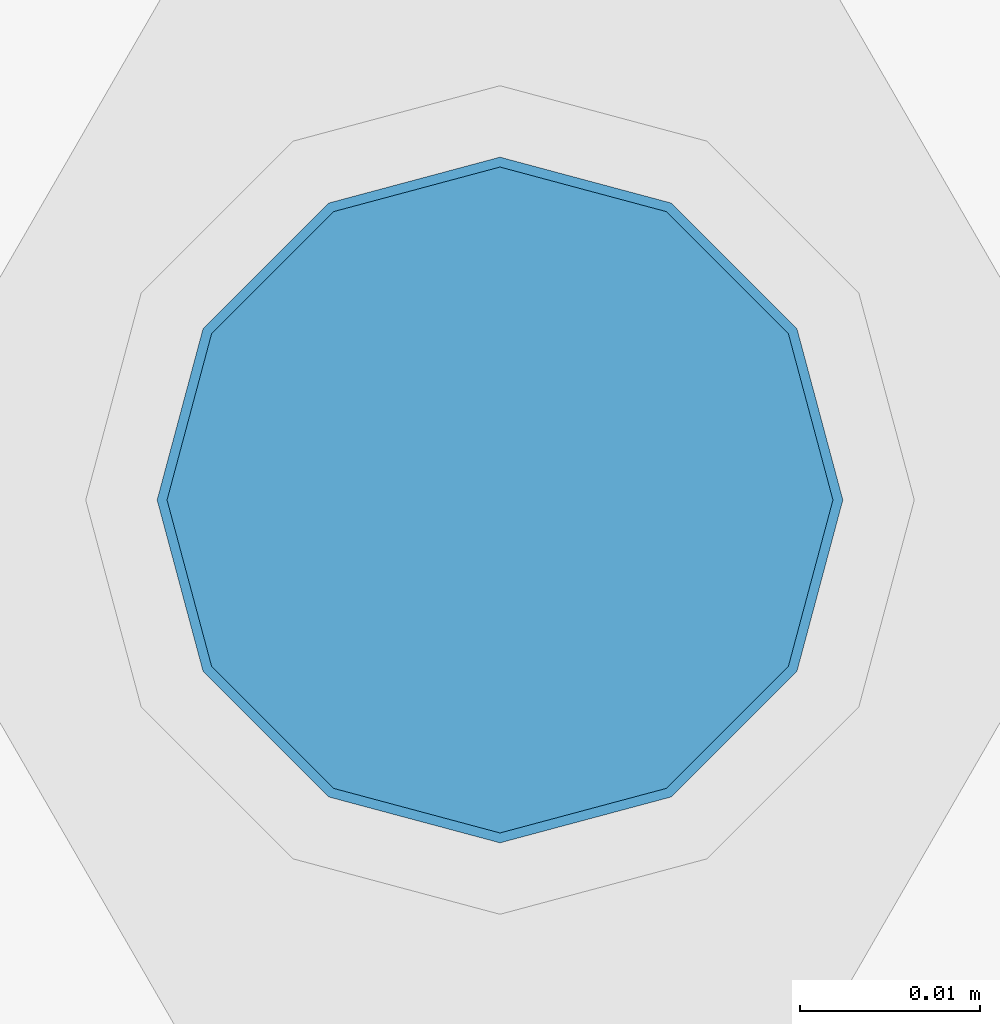
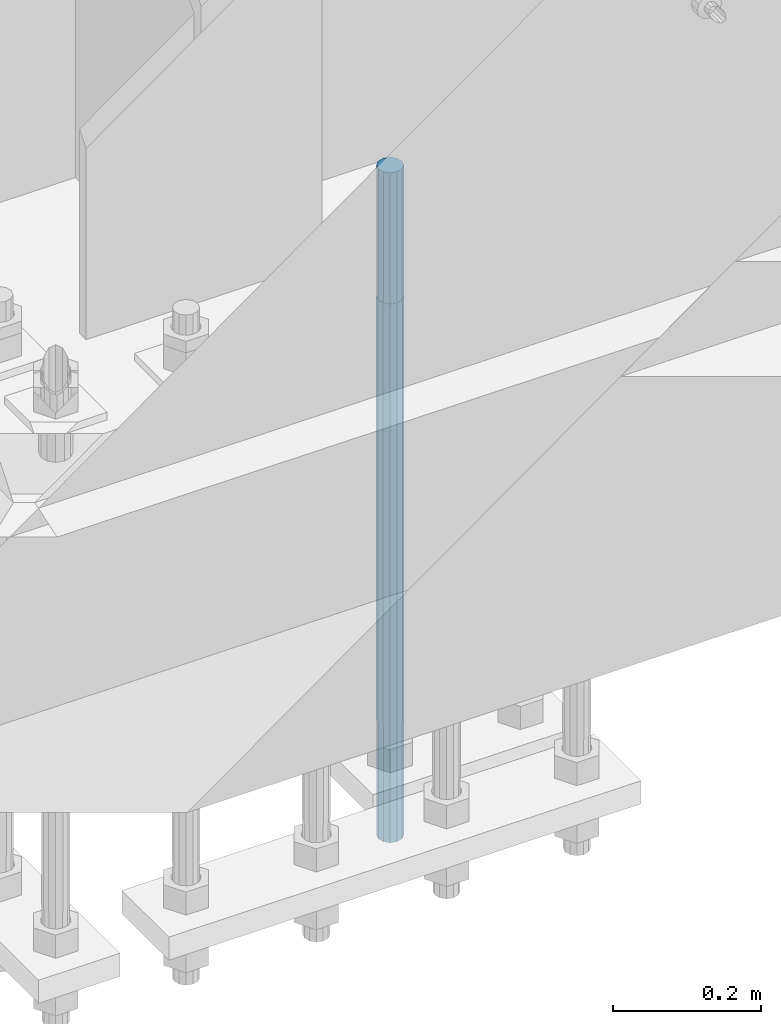
# One storey, part 1281 of 3843: 1 column, 1 element without a shape of its own.
"""IFC2X3 building model written with IfcOpenShell, lengths in millimetres."""

from ifc_helpers import new_model, si_unit, frame, origin_with_axes, place, context, subcontext, project, spatial, faceted_brep, material, type_object, element, aggregate, save


model = new_model("IFC2X3")

# Units and contexts
model_context = context("Model", 3, precision=1e-05, world=origin_with_axes())
body_context = subcontext(model_context, "Body", "Model", "MODEL_VIEW")
ifc_project = project(units=[si_unit("LENGTHUNIT", "METRE", prefix="MILLI"), si_unit("AREAUNIT", "SQUARE_METRE"), si_unit("VOLUMEUNIT", "CUBIC_METRE"), si_unit("MASSUNIT", "GRAM", prefix="KILO"), si_unit("TIMEUNIT", "SECOND"), si_unit("PLANEANGLEUNIT", "RADIAN"), si_unit("SOLIDANGLEUNIT", "STERADIAN"), si_unit("THERMODYNAMICTEMPERATUREUNIT", "DEGREE_CELSIUS"), si_unit("LUMINOUSINTENSITYUNIT", "LUMEN")], contexts=[model_context])

# Site, building, storey
site_placement = place(None, origin_with_axes())
site = spatial("IfcSite", under=ifc_project, at=site_placement, CompositionType="ELEMENT")
building_placement = place(site_placement, origin_with_axes())
building = spatial("IfcBuilding", under=site, at=building_placement, Name="Undefined", CompositionType="ELEMENT")
storey_placement = place(building_placement, origin_with_axes())
storey = spatial("IfcBuildingStorey", under=building, at=storey_placement, Name="Undefined", CompositionType="ELEMENT", Elevation=0.0)

# Assembly, column
assembly_placement = place(storey_placement, origin_with_axes())
assembly = element("IfcElementAssembly", 1, at=assembly_placement, inside=storey, Name="TEMPLATE", AssemblyPlace="NOTDEFINED", PredefinedType="RIGID_FRAME")
ifc_material = material(Name="Undefined/F1554-GR.55")
column_type = type_object("IfcColumnType", PredefinedType="NOTDEFINED")
column_placement = place(assembly_placement, frame((42367.2, 25463.5, 29565.6), z_axis=(0.0, 1.0, 0.0), x_axis=(0.0, 0.0, -1.0)))
column = element("IfcColumn", 2, at=column_placement, type_object=column_type, material=ifc_material, Name="ANCHOR_ROD", context=body_context, shape_type="Brep", body=[
    faceted_brep([(-215.899999999998, -16.0214699700118, 9.25), (-215.899999999998, -9.25, 16.0214699700155), (-215.899999999998, 0.0, 18.5), (-215.899999999998, 9.25, 16.0214699700155), (-215.899999999998, 16.0214699700118, 9.25), (-215.899999999998, 18.5, 0.0), (-215.899999999998, 16.0214699700118, -9.25), (-215.899999999998, 9.25, -16.0214699700155), (-215.899999999998, 0.0, -18.5), (-215.899999999998, -9.25, -16.0214699700155), (-215.899999999998, -16.0214699700118, -9.25), (-215.899999999998, -18.5, 0.0), (0.0, 18.5, 0.0), (0.0, 16.0214699700118, -9.25), (0.0, 9.25, -16.0214699700155), (0.0, 0.0, -18.5), (0.0, -9.25, -16.0214699700155), (0.0, -16.0214699700118, -9.25), (0.0, -18.5, 0.0), (0.0, -16.0214699700118, 9.25), (0.0, -9.25, 16.0214699700155), (0.0, 0.0, 18.5), (0.0, 9.25, 16.0214699700155), (0.0, 16.0214699700118, 9.25), (0.0, -16.4977839420972, 9.52500000000146), (0.0, -9.52500000000146, 16.4977839420972), (0.0, 0.0, 19.0499989999989), (0.0, 9.52500000000146, 16.4977839420972), (0.0, 16.4977839420972, 9.52500000000146), (0.0, 19.0500000000029, 0.0), (0.0, 16.4977839420972, -9.52500000000146), (0.0, 9.52500000000146, -16.4977839420972), (0.0, 0.0, -19.0499989999989), (0.0, -9.52500000000146, -16.4977839420972), (0.0, -16.4977839420972, -9.52500000000146), (0.0, -19.0500000000029, 0.0), (698.5, -19.0499999999993, 0.0), (698.5, -16.4977839420935, 9.52499999999418), (698.5, -9.52500000000146, 16.4977839420899), (698.5, 0.0, 19.0500000000029), (698.5, 9.52500000000146, 16.4977839420899), (698.5, 16.4977839420935, 9.52499999999418), (698.5, 19.0499999999993, 0.0), (698.5, 16.4977839420935, -9.52499999999418), (698.5, 9.52500000000146, -16.4977839420899), (698.5, 0.0, -19.0500000000029), (698.5, -9.52500000000146, -16.4977839420899), (698.5, -16.4977839420935, -9.52499999999418), (698.5, -9.25, 16.0214699700155), (698.5, 0.0, 18.5), (698.5, 9.25, 16.0214699700155), (698.5, 16.0214699700118, 9.25), (698.5, 18.5, 0.0), (698.5, 16.0214699700118, -9.25), (698.5, 9.25, -16.0214699700155), (698.5, 0.0, -18.5), (698.5, -9.25, -16.0214699700155), (698.5, -16.0214699700118, -9.25), (698.5, -18.5, 0.0), (698.5, -16.0214699700118, 9.25), (889.0, -9.25, -16.0214699700155), (889.0, 0.0, -18.5), (889.0, 9.25, -16.0214699700155), (889.0, 16.0214699700118, -9.25), (889.0, 18.5, 0.0), (889.0, 16.0214699700118, 9.25), (889.0, 9.25, 16.0214699700155), (889.0, 0.0, 18.5), (889.0, -9.25, 16.0214699700155), (889.0, -16.0214699700118, 9.25), (889.0, -18.5, 0.0), (889.0, -16.0214699700118, -9.25)], [[[0, 1, 2, 3, 4, 5, 6, 7, 8, 9, 10, 11]], [[6, 5, 12, 13]], [[7, 6, 13, 14]], [[8, 7, 14, 15]], [[9, 8, 15, 16]], [[10, 9, 16, 17]], [[11, 10, 17, 18]], [[0, 11, 18, 19]], [[1, 0, 19, 20]], [[2, 1, 20, 21]], [[3, 2, 21, 22]], [[4, 3, 22, 23]], [[5, 4, 23, 12]], [[24, 25, 26, 27, 28, 29, 30, 31, 32, 33, 34, 35], [22, 21, 20, 19, 18, 17, 16, 15, 14, 13, 12, 23]], [[24, 35, 36, 37]], [[25, 24, 37, 38]], [[26, 25, 38, 39]], [[27, 26, 39, 40]], [[28, 27, 40, 41]], [[29, 28, 41, 42]], [[30, 29, 42, 43]], [[31, 30, 43, 44]], [[32, 31, 44, 45]], [[33, 32, 45, 46]], [[34, 33, 46, 47]], [[35, 34, 47, 36]], [[46, 45, 44, 43, 42, 41, 40, 39, 38, 37, 36, 47], [48, 49, 50, 51, 52, 53, 54, 55, 56, 57, 58, 59]], [[60, 61, 62, 63, 64, 65, 66, 67, 68, 69, 70, 71]], [[68, 67, 49, 48]], [[69, 68, 48, 59]], [[70, 69, 59, 58]], [[71, 70, 58, 57]], [[60, 71, 57, 56]], [[61, 60, 56, 55]], [[62, 61, 55, 54]], [[63, 62, 54, 53]], [[64, 63, 53, 52]], [[65, 64, 52, 51]], [[66, 65, 51, 50]], [[67, 66, 50, 49]]]),
])
aggregate(assembly, [column])

save(model, "model.ifc")
